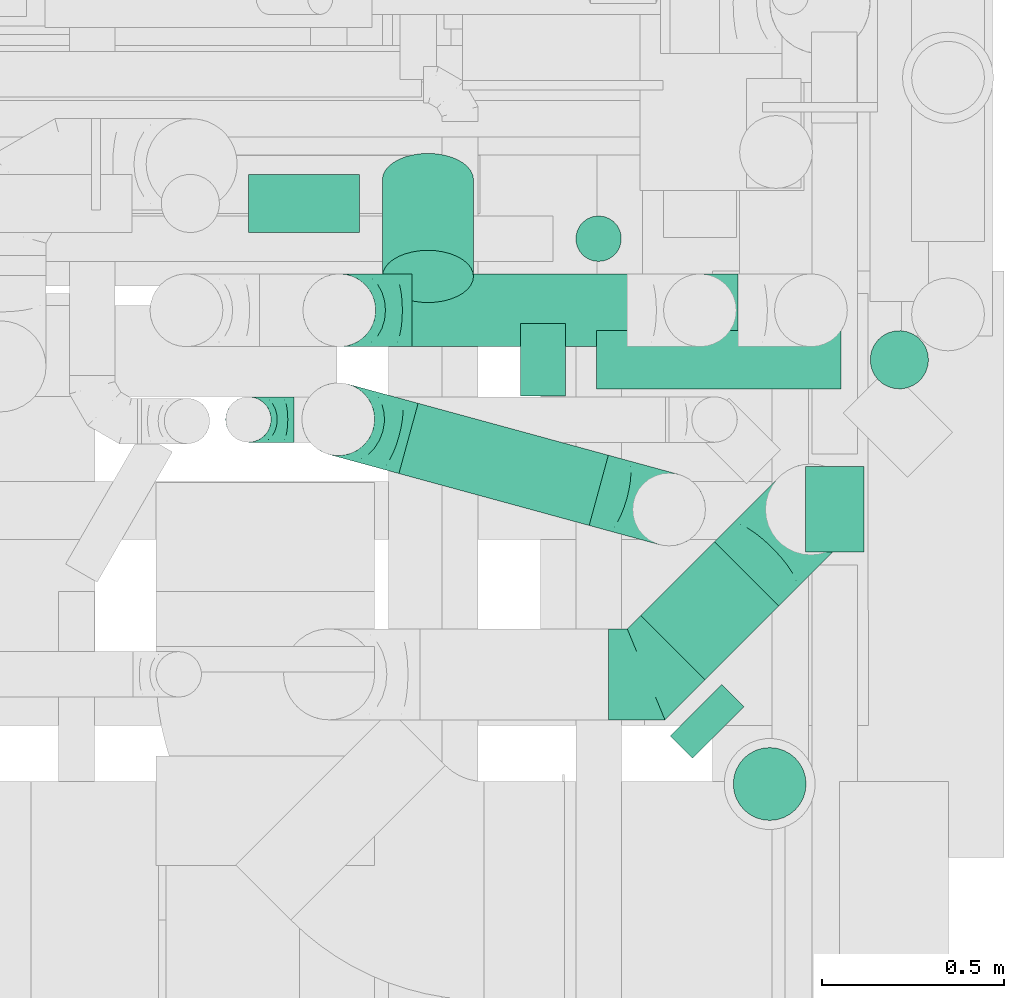
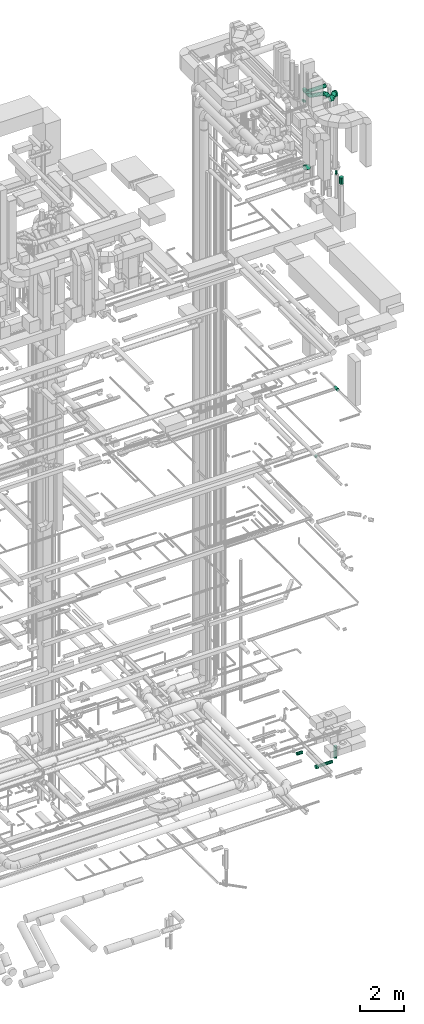
# One storey, part 300 of 337: 12 flow segments, 6 flow fittings.
"""IFC2X3 building model written with IfcOpenShell, lengths in millimetres."""

from ifc_helpers import new_model, entity, si_unit, converted_unit, derived_unit, direction, frame, origin, origin_2d_with_axis, place, context, subcontext, project, spatial, circle, extrude, faceted_brep, source, transform, mapped, material, type_object, type_shapes, element, save


model = new_model("IFC2X3")

# Units and contexts
model_context = context("Model", 3, precision=0.01, world=origin(), true_north=direction((6.12303176911189e-17, 1.0)))
body_context = subcontext(model_context, "Body", "Model", "MODEL_VIEW")
ifc_project = project(units=[si_unit("LENGTHUNIT", "METRE", prefix="MILLI"), si_unit("AREAUNIT", "SQUARE_METRE"), si_unit("VOLUMEUNIT", "CUBIC_METRE"), converted_unit("PLANEANGLEUNIT", "DEGREE", entity("IfcRatioMeasure", 0.0174532925199433), si_unit("PLANEANGLEUNIT", "RADIAN"), dimensions=[0, 0, 0, 0, 0, 0, 0]), si_unit("MASSUNIT", "GRAM", prefix="KILO"), derived_unit("MASSDENSITYUNIT", [(si_unit("MASSUNIT", "GRAM", prefix="KILO"), 1), (si_unit("LENGTHUNIT", "METRE"), -3)]), derived_unit("MOMENTOFINERTIAUNIT", [(si_unit("LENGTHUNIT", "METRE"), 4)]), si_unit("TIMEUNIT", "SECOND"), si_unit("FREQUENCYUNIT", "HERTZ"), si_unit("THERMODYNAMICTEMPERATUREUNIT", "DEGREE_CELSIUS"), derived_unit("THERMALTRANSMITTANCEUNIT", [(si_unit("MASSUNIT", "GRAM", prefix="KILO"), 1), (si_unit("THERMODYNAMICTEMPERATUREUNIT", "KELVIN"), -1), (si_unit("TIMEUNIT", "SECOND"), -3)]), derived_unit("VOLUMETRICFLOWRATEUNIT", [(si_unit("LENGTHUNIT", "METRE"), 3), (si_unit("TIMEUNIT", "SECOND"), -1)]), derived_unit("MASSFLOWRATEUNIT", [(si_unit("MASSUNIT", "GRAM", prefix="KILO"), 1), (si_unit("TIMEUNIT", "SECOND"), -1)]), derived_unit("ROTATIONALFREQUENCYUNIT", [(si_unit("TIMEUNIT", "SECOND"), -1)]), si_unit("ELECTRICCURRENTUNIT", "AMPERE"), si_unit("ELECTRICVOLTAGEUNIT", "VOLT"), si_unit("POWERUNIT", "WATT"), si_unit("FORCEUNIT", "NEWTON", prefix="KILO"), si_unit("ILLUMINANCEUNIT", "LUX"), si_unit("LUMINOUSFLUXUNIT", "LUMEN"), si_unit("LUMINOUSINTENSITYUNIT", "CANDELA"), derived_unit("USERDEFINED", [(si_unit("MASSUNIT", "GRAM", prefix="KILO"), -1), (si_unit("LENGTHUNIT", "METRE"), -2), (si_unit("TIMEUNIT", "SECOND"), 3), (si_unit("LUMINOUSFLUXUNIT", "LUMEN"), 1)]), derived_unit("LINEARVELOCITYUNIT", [(si_unit("LENGTHUNIT", "METRE"), 1), (si_unit("TIMEUNIT", "SECOND"), -1)]), si_unit("PRESSUREUNIT", "PASCAL"), derived_unit("USERDEFINED", [(si_unit("LENGTHUNIT", "METRE"), -2), (si_unit("MASSUNIT", "GRAM", prefix="KILO"), 1), (si_unit("TIMEUNIT", "SECOND"), -2)]), derived_unit("LINEARFORCEUNIT", [(si_unit("MASSUNIT", "GRAM", prefix="KILO"), 1), (si_unit("LENGTHUNIT", "METRE"), 1), (si_unit("TIMEUNIT", "SECOND"), -2), (si_unit("LENGTHUNIT", "METRE"), -1)]), derived_unit("PLANARFORCEUNIT", [(si_unit("MASSUNIT", "GRAM", prefix="KILO"), 1), (si_unit("LENGTHUNIT", "METRE"), 1), (si_unit("TIMEUNIT", "SECOND"), -2), (si_unit("LENGTHUNIT", "METRE"), -2)])], contexts=[model_context])

# Site, building, storey
site_placement = place(None, origin())
site = spatial("IfcSite", under=ifc_project, at=site_placement, CompositionType="ELEMENT")
building_placement = place(site_placement, origin())
building = spatial("IfcBuilding", under=site, at=building_placement, CompositionType="ELEMENT")
storey_placement = place(building_placement, origin())
storey = spatial("IfcBuildingStorey", under=building, at=storey_placement, CompositionType="ELEMENT", Elevation=0.0)

# Flow segments
duct_segment_type = type_object("IfcDuctSegmentType", PredefinedType="NOTDEFINED")
flow_segment_1_placement = place(storey_placement, frame((72879.66, 9130.21, -1618.0)))
element("IfcFlowSegment", 1, at=flow_segment_1_placement, inside=storey, type_object=duct_segment_type, context=body_context, shape_type="SweptSolid", body=[
    extrude(circle(Radius=80.0, at=origin_2d_with_axis()), frame((81.6, 81.6, 0.0)), (0.0, 0.0, 1.0), 658.000000000009),
])
flow_segment_2_placement = place(storey_placement, frame((71921.25, 9110.21, -1879.6)))
element("IfcFlowSegment", 2, at=flow_segment_2_placement, inside=storey, type_object=duct_segment_type, context=body_context, shape_type="SweptSolid", body=[
    extrude(circle(Radius=100.0, at=origin_2d_with_axis()), frame((0.0, 101.6, 101.6), z_axis=(1.0, 0.0, 0.0), x_axis=(0.0, 1.0, 0.0)), (0.0, 0.0, 1.0), 123.655124999988),
])
flow_segment_3_placement = place(storey_placement, frame((72129.91, 9130.21, -1859.6)))
element("IfcFlowSegment", 3, at=flow_segment_3_placement, inside=storey, type_object=duct_segment_type, context=body_context, shape_type="SweptSolid", body=[
    extrude(circle(Radius=80.0, at=origin_2d_with_axis()), frame((0.0, 81.6, 81.6), z_axis=(1.0, 0.0, 0.0), x_axis=(0.0, 1.0, 0.0)), (0.0, 0.0, 1.0), 671.344875000004),
])
flow_segment_4_placement = place(storey_placement, frame((71174.45, 9559.41, -1131.6)))
element("IfcFlowSegment", 4, at=flow_segment_4_placement, inside=storey, type_object=duct_segment_type, context=body_context, shape_type="SweptSolid", body=[
    extrude(circle(Radius=80.0, at=origin_2d_with_axis()), frame((0.0, 81.6, 81.6), z_axis=(1.0, 0.0, 0.0), x_axis=(0.0, -1.0, 0.0)), (0.0, 0.0, 1.0), 304.584560000007),
])
flow_segment_5_placement = place(storey_placement, frame((72702.56, 8683.57, 19068.4)))
element("IfcFlowSegment", 5, at=flow_segment_5_placement, inside=storey, type_object=duct_segment_type, context=body_context, shape_type="SweptSolid", body=[
    extrude(circle(Radius=80.0, at=origin_2d_with_axis()), frame((81.6, 0.0, 81.6), z_axis=(0.0, 1.0, 0.0), x_axis=(-1.0, 0.0, 0.0)), (0.0, 0.0, 1.0), 235.0),
])
flow_segment_6_placement = place(storey_placement, frame((72071.32, 9480.25, 15125.0)))
element("IfcFlowSegment", 6, at=flow_segment_6_placement, inside=storey, type_object=duct_segment_type, context=body_context, shape_type="SweptSolid", body=[
    extrude(circle(Radius=62.5, at=origin_2d_with_axis()), frame((64.1, 64.1, 0.0), z_axis=(0.0, 0.0, 1.0), x_axis=(0.0, 1.0, 0.0)), (0.0, 0.0, 1.0), 99.9999750292887),
])
flow_segment_7_placement = place(storey_placement, frame((71585.61, 8755.33, 35588.4)))
element("IfcFlowSegment", 7, at=flow_segment_7_placement, inside=storey, type_object=duct_segment_type, context=body_context, shape_type="SweptSolid", body=[
    extrude(circle(Radius=100.0, at=origin_2d_with_axis()), frame((27.92, 240.6, 101.6), z_axis=(0.964726810166191, -0.263253075474089, 0.0), x_axis=(-0.263253075474089, -0.964726810166191, 0.0)), (0.0, 0.0, 1.0), 541.414851509335),
])
flow_segment_8_placement = place(storey_placement, frame((71623.49, 9246.15, 35598.4)))
element("IfcFlowSegment", 8, at=flow_segment_8_placement, inside=storey, type_object=duct_segment_type, context=body_context, shape_type="SweptSolid", body=[
    extrude(circle(Radius=100.0, at=origin_2d_with_axis()), frame((0.0, 101.6, 101.6), z_axis=(1.0, 0.0, 0.0), x_axis=(0.0, 1.0, 0.0)), (0.0, 0.0, 1.0), 895.000000000004),
])
flow_segment_9_placement = place(storey_placement, frame((72330.33, 8116.09, 31498.4)))
element("IfcFlowSegment", 9, at=flow_segment_9_placement, inside=storey, type_object=duct_segment_type, context=body_context, shape_type="SweptSolid", body=[
    extrude(circle(Radius=100.0, at=origin_2d_with_axis()), frame((133.43, 72.31, 101.6), z_axis=(-0.707106781186472, 0.707106781186623, 0.0), x_axis=(-0.707106781186623, -0.707106781186472, 0.0)), (0.0, 0.0, 1.0), 86.4466094067538),
])
flow_segment_10_placement = place(storey_placement, frame((72503.59, 7945.38, 31040.0)))
element("IfcFlowSegment", 10, at=flow_segment_10_placement, inside=storey, type_object=duct_segment_type, context=body_context, shape_type="SweptSolid", body=[
    extrude(circle(Radius=100.0, at=origin_2d_with_axis()), frame((101.6, 101.6, 0.0), z_axis=(0.0, 0.0, 1.0), x_axis=(-0.707106781186531, 0.707106781186564, 0.0)), (0.0, 0.0, 1.0), 360.0),
])
flow_segment_11_placement = place(storey_placement, frame((71540.22, 9367.35, 31141.22)))
element("IfcFlowSegment", 11, at=flow_segment_11_placement, inside=storey, type_object=duct_segment_type, context=body_context, shape_type="SweptSolid", body=[
    extrude(circle(Radius=125.0, at=origin_2d_with_axis()), frame((126.6, 339.49, 103.99), z_axis=(0.0, -0.819152044288992, 0.573576436351046), x_axis=(-1.0, 0.0, 0.0)), (0.0, 0.0, 1.0), 324.967851138154),
])
flow_segment_12_placement = place(storey_placement, frame((72249.1, 8331.36, 35548.4)))
element("IfcFlowSegment", 12, at=flow_segment_12_placement, inside=storey, type_object=duct_segment_type, context=body_context, shape_type="SweptSolid", body=[
    extrude(circle(Radius=125.0, at=origin_2d_with_axis()), frame((89.98, 89.98, 126.6), z_axis=(0.707106781186557, 0.707106781186538, 0.0), x_axis=(0.707106781186538, -0.707106781186557, 0.0)), (0.0, 0.0, 1.0), 286.554549002885),
])

# Flow fittings
ifc_material = material()
duct_fitting_type_1 = type_object("IfcDuctFittingType", PredefinedType="NOTDEFINED", material=ifc_material)
shared_shape_1 = source(origin(), body_context, "Body", "Brep", [
    faceted_brep([(-250.0, 0.0, -125.0), (-250.0, -32.35, -120.74), (-250.0, -62.5, -108.25), (-250.0, -88.39, -88.39), (-250.0, -108.25, -62.5), (-250.0, -120.74, -32.35), (-250.0, -125.0, 0.0), (-250.0, -120.74, 32.35), (-250.0, -108.25, 62.5), (-250.0, -88.39, 88.39), (-250.0, -62.5, 108.25), (-250.0, -32.35, 120.74), (-250.0, 0.0, 125.0), (-250.0, 32.35, 120.74), (-250.0, 62.5, 108.25), (-250.0, 88.39, 88.39), (-250.0, 108.25, 62.5), (-250.0, 120.74, 32.35), (-250.0, 125.0, 0.0), (-250.0, 120.74, -32.35), (-250.0, 108.25, -62.5), (-250.0, 88.39, -88.39), (-250.0, 62.5, -108.25), (-250.0, 32.35, -120.74), (-191.68, 32.35, 120.74), (-199.76, 62.5, 108.25), (-183.01, 0.0, 125.0), (-206.7, 88.39, 88.39), (-215.37, 120.74, 32.35), (-216.51, 125.0, 0.0), (-212.02, 108.25, 62.5), (-212.02, 108.25, -62.5), (-206.7, 88.39, -88.39), (-215.37, 120.74, -32.35), (-191.68, 32.35, -120.74), (-183.01, 0.0, -125.0), (-199.76, 62.5, -108.25), (-174.34, -32.35, -120.74), (-166.27, -62.5, -108.25), (-159.33, -88.39, -88.39), (-154.01, -108.25, -62.5), (-150.66, -120.74, -32.35), (-149.52, -125.0, 0.0), (-150.66, -120.74, 32.35), (-154.01, -108.25, 62.5), (-159.33, -88.39, 88.39), (-166.27, -62.5, 108.25), (-174.34, -32.35, 120.74), (-90.67, 90.67, 120.74), (-112.74, 112.74, 108.25), (-66.99, 66.99, 125.0), (-131.69, 131.69, 88.39), (-146.23, 146.23, 62.5), (-155.38, 155.38, 32.35), (-158.49, 158.49, 0.0), (-155.38, 155.38, -32.35), (-146.23, 146.23, -62.5), (-131.69, 131.69, -88.39), (-90.67, 90.67, -120.74), (-66.99, 66.99, -125.0), (-112.74, 112.74, -108.25), (-43.3, 43.3, -120.74), (-21.23, 21.23, -108.25), (-2.28, 2.28, -88.39), (12.26, -12.26, -62.5), (21.4, -21.4, -32.35), (24.52, -24.52, 0.0), (21.4, -21.4, 32.35), (12.26, -12.26, 62.5), (-2.28, 2.28, 88.39), (-21.23, 21.23, 108.25), (-43.3, 43.3, 120.74), (-32.35, 191.68, 120.74), (-62.5, 199.76, 108.25), (0.0, 183.01, 125.0), (-88.39, 206.7, 88.39), (-108.25, 212.02, 62.5), (-120.74, 215.37, 32.35), (-125.0, 216.51, 0.0), (-120.74, 215.37, -32.35), (-108.25, 212.02, -62.5), (-88.39, 206.7, -88.39), (-32.35, 191.68, -120.74), (0.0, 183.01, -125.0), (-62.5, 199.76, -108.25), (32.35, 174.34, -120.74), (62.5, 166.27, -108.25), (88.39, 159.33, -88.39), (108.25, 154.01, -62.5), (120.74, 150.66, -32.35), (125.0, 149.52, 0.0), (120.74, 150.66, 32.35), (108.25, 154.01, 62.5), (88.39, 159.33, 88.39), (62.5, 166.27, 108.25), (32.35, 174.34, 120.74), (-32.35, 250.0, -120.74), (-62.5, 250.0, -108.25), (-88.39, 250.0, -88.39), (-108.25, 250.0, -62.5), (-120.74, 250.0, -32.35), (-125.0, 250.0, 0.0), (-120.74, 250.0, 32.35), (-108.25, 250.0, 62.5), (-88.39, 250.0, 88.39), (-62.5, 250.0, 108.25), (-32.35, 250.0, 120.74), (0.0, 250.0, 125.0), (32.35, 250.0, 120.74), (62.5, 250.0, 108.25), (88.39, 250.0, 88.39), (108.25, 250.0, 62.5), (120.74, 250.0, 32.35), (125.0, 250.0, 0.0), (120.74, 250.0, -32.35), (108.25, 250.0, -62.5), (88.39, 250.0, -88.39), (62.5, 250.0, -108.25), (32.35, 250.0, -120.74), (0.0, 250.0, -125.0)], [[[0, 1, 2, 3, 4, 5, 6, 7, 8, 9, 10, 11, 12, 13, 14, 15, 16, 17, 18, 19, 20, 21, 22, 23]], [[24, 25, 14, 13]], [[26, 24, 13, 12]], [[14, 25, 27, 15]], [[28, 29, 18, 17]], [[30, 28, 17, 16]], [[15, 27, 30, 16]], [[20, 31, 32, 21]], [[33, 31, 20, 19]], [[18, 29, 33, 19]], [[34, 35, 0, 23]], [[36, 34, 23, 22]], [[21, 32, 36, 22]], [[1, 0, 35, 37]], [[2, 1, 37, 38]], [[38, 39, 3, 2]], [[5, 4, 40, 41]], [[6, 5, 41, 42]], [[39, 40, 4, 3]], [[6, 42, 43, 7]], [[7, 43, 44, 8]], [[8, 44, 45, 9]], [[9, 45, 46, 10]], [[10, 46, 47, 11]], [[26, 12, 11, 47]], [[48, 49, 25, 24]], [[50, 48, 24, 26]], [[27, 25, 49, 51]], [[52, 53, 28, 30]], [[51, 52, 30, 27]], [[29, 28, 53, 54]], [[55, 56, 31, 33]], [[54, 55, 33, 29]], [[32, 31, 56, 57]], [[58, 59, 35, 34]], [[60, 58, 34, 36]], [[57, 60, 36, 32]], [[37, 35, 59, 61]], [[38, 37, 61, 62]], [[39, 38, 62, 63]], [[41, 40, 64, 65]], [[42, 41, 65, 66]], [[63, 64, 40, 39]], [[43, 42, 66, 67]], [[44, 43, 67, 68]], [[68, 69, 45, 44]], [[46, 45, 69, 70]], [[47, 46, 70, 71]], [[26, 47, 71, 50]], [[72, 73, 49, 48]], [[74, 72, 48, 50]], [[51, 49, 73, 75]], [[76, 77, 53, 52]], [[75, 76, 52, 51]], [[54, 53, 77, 78]], [[79, 80, 56, 55]], [[78, 79, 55, 54]], [[57, 56, 80, 81]], [[82, 83, 59, 58]], [[84, 82, 58, 60]], [[81, 84, 60, 57]], [[61, 59, 83, 85]], [[62, 61, 85, 86]], [[63, 62, 86, 87]], [[65, 64, 88, 89]], [[66, 65, 89, 90]], [[87, 88, 64, 63]], [[67, 66, 90, 91]], [[68, 67, 91, 92]], [[92, 93, 69, 68]], [[70, 69, 93, 94]], [[71, 70, 94, 95]], [[50, 71, 95, 74]], [[96, 97, 98, 99, 100, 101, 102, 103, 104, 105, 106, 107, 108, 109, 110, 111, 112, 113, 114, 115, 116, 117, 118, 119]], [[72, 74, 107, 106]], [[73, 72, 106, 105]], [[75, 73, 105, 104]], [[77, 76, 103, 102]], [[78, 77, 102, 101]], [[75, 104, 103, 76]], [[78, 101, 100, 79]], [[79, 100, 99, 80]], [[80, 99, 98, 81]], [[84, 97, 96, 82]], [[82, 96, 119, 83]], [[84, 81, 98, 97]], [[83, 119, 118, 85]], [[85, 118, 117, 86]], [[116, 87, 86, 117]], [[88, 115, 114, 89]], [[89, 114, 113, 90]], [[115, 88, 87, 116]], [[91, 90, 113, 112]], [[92, 91, 112, 111]], [[111, 110, 93, 92]], [[95, 94, 109, 108]], [[74, 95, 108, 107]], [[110, 109, 94, 93]]]),
])
type_shapes(duct_fitting_type_1, [shared_shape_1])
flow_fitting_1_placement = place(storey_placement, frame((72718.49, 8800.75, 35675.0), z_axis=(-0.707106781186577, 0.707106781186518, 0.0), x_axis=(0.707106781186518, 0.707106781186577, 0.0)))
element("IfcFlowFitting", 13, at=flow_fitting_1_placement, inside=storey, type_object=duct_fitting_type_1, material=ifc_material, context=body_context, shape_type="MappedRepresentation", body=[
    mapped(shared_shape_1, transform((0.0, 0.0, 0.0), scale=1.0)),
])
duct_fitting_type_2 = type_object("IfcDuctFittingType", PredefinedType="NOTDEFINED", material=ifc_material)
shared_shape_2 = source(origin(), body_context, "Body", "Brep", [
    faceted_brep([(-200.0, 0.0, -100.0), (-200.0, -25.88, -96.59), (-200.0, -50.0, -86.6), (-200.0, -70.71, -70.71), (-200.0, -86.6, -50.0), (-200.0, -96.59, -25.88), (-200.0, -100.0, 0.0), (-200.0, -96.59, 25.88), (-200.0, -86.6, 50.0), (-200.0, -70.71, 70.71), (-200.0, -50.0, 86.6), (-200.0, -25.88, 96.59), (-200.0, 0.0, 100.0), (-200.0, 25.88, 96.59), (-200.0, 50.0, 86.6), (-200.0, 70.71, 70.71), (-200.0, 86.6, 50.0), (-200.0, 96.59, 25.88), (-200.0, 100.0, 0.0), (-200.0, 96.59, -25.88), (-200.0, 86.6, -50.0), (-200.0, 70.71, -70.71), (-200.0, 50.0, -86.6), (-200.0, 25.88, -96.59), (-153.35, 25.88, 96.59), (-159.81, 50.0, 86.6), (-146.41, 0.0, 100.0), (-165.36, 70.71, 70.71), (-172.29, 96.59, 25.88), (-173.21, 100.0, 0.0), (-169.62, 86.6, 50.0), (-169.62, 86.6, -50.0), (-165.36, 70.71, -70.71), (-172.29, 96.59, -25.88), (-153.35, 25.88, -96.59), (-146.41, 0.0, -100.0), (-159.81, 50.0, -86.6), (-139.48, -25.88, -96.59), (-133.01, -50.0, -86.6), (-127.46, -70.71, -70.71), (-123.21, -86.6, -50.0), (-120.53, -96.59, -25.88), (-119.62, -100.0, 0.0), (-120.53, -96.59, 25.88), (-123.21, -86.6, 50.0), (-127.46, -70.71, 70.71), (-133.01, -50.0, 86.6), (-139.48, -25.88, 96.59), (-72.54, 72.54, 96.59), (-90.19, 90.19, 86.6), (-53.59, 53.59, 100.0), (-105.35, 105.35, 70.71), (-116.99, 116.99, 50.0), (-124.3, 124.3, 25.88), (-126.79, 126.79, 0.0), (-124.3, 124.3, -25.88), (-116.99, 116.99, -50.0), (-105.35, 105.35, -70.71), (-72.54, 72.54, -96.59), (-53.59, 53.59, -100.0), (-90.19, 90.19, -86.6), (-34.64, 34.64, -96.59), (-16.99, 16.99, -86.6), (-1.83, 1.83, -70.71), (9.81, -9.81, -50.0), (17.12, -17.12, -25.88), (19.62, -19.62, 0.0), (17.12, -17.12, 25.88), (9.81, -9.81, 50.0), (-1.83, 1.83, 70.71), (-16.99, 16.99, 86.6), (-34.64, 34.64, 96.59), (-25.88, 153.35, 96.59), (-50.0, 159.81, 86.6), (0.0, 146.41, 100.0), (-70.71, 165.36, 70.71), (-86.6, 169.62, 50.0), (-96.59, 172.29, 25.88), (-100.0, 173.21, 0.0), (-96.59, 172.29, -25.88), (-86.6, 169.62, -50.0), (-70.71, 165.36, -70.71), (-25.88, 153.35, -96.59), (0.0, 146.41, -100.0), (-50.0, 159.81, -86.6), (25.88, 139.48, -96.59), (50.0, 133.01, -86.6), (70.71, 127.46, -70.71), (86.6, 123.21, -50.0), (96.59, 120.53, -25.88), (100.0, 119.62, 0.0), (96.59, 120.53, 25.88), (86.6, 123.21, 50.0), (70.71, 127.46, 70.71), (50.0, 133.01, 86.6), (25.88, 139.48, 96.59), (-25.88, 200.0, -96.59), (-50.0, 200.0, -86.6), (-70.71, 200.0, -70.71), (-86.6, 200.0, -50.0), (-96.59, 200.0, -25.88), (-100.0, 200.0, 0.0), (-96.59, 200.0, 25.88), (-86.6, 200.0, 50.0), (-70.71, 200.0, 70.71), (-50.0, 200.0, 86.6), (-25.88, 200.0, 96.59), (0.0, 200.0, 100.0), (25.88, 200.0, 96.59), (50.0, 200.0, 86.6), (70.71, 200.0, 70.71), (86.6, 200.0, 50.0), (96.59, 200.0, 25.88), (100.0, 200.0, 0.0), (96.59, 200.0, -25.88), (86.6, 200.0, -50.0), (70.71, 200.0, -70.71), (50.0, 200.0, -86.6), (25.88, 200.0, -96.59), (0.0, 200.0, -100.0)], [[[0, 1, 2, 3, 4, 5, 6, 7, 8, 9, 10, 11, 12, 13, 14, 15, 16, 17, 18, 19, 20, 21, 22, 23]], [[24, 25, 14, 13]], [[26, 24, 13, 12]], [[14, 25, 27, 15]], [[28, 29, 18, 17]], [[30, 28, 17, 16]], [[15, 27, 30, 16]], [[20, 31, 32, 21]], [[33, 31, 20, 19]], [[18, 29, 33, 19]], [[34, 35, 0, 23]], [[36, 34, 23, 22]], [[32, 36, 22, 21]], [[1, 0, 35, 37]], [[2, 1, 37, 38]], [[38, 39, 3, 2]], [[5, 4, 40, 41]], [[6, 5, 41, 42]], [[39, 40, 4, 3]], [[6, 42, 43, 7]], [[7, 43, 44, 8]], [[8, 44, 45, 9]], [[9, 45, 46, 10]], [[10, 46, 47, 11]], [[26, 12, 11, 47]], [[48, 49, 25, 24]], [[50, 48, 24, 26]], [[27, 25, 49, 51]], [[52, 53, 28, 30]], [[51, 52, 30, 27]], [[29, 28, 53, 54]], [[55, 56, 31, 33]], [[54, 55, 33, 29]], [[32, 31, 56, 57]], [[58, 59, 35, 34]], [[60, 58, 34, 36]], [[57, 60, 36, 32]], [[37, 35, 59, 61]], [[38, 37, 61, 62]], [[39, 38, 62, 63]], [[41, 40, 64, 65]], [[42, 41, 65, 66]], [[63, 64, 40, 39]], [[43, 42, 66, 67]], [[44, 43, 67, 68]], [[68, 69, 45, 44]], [[46, 45, 69, 70]], [[47, 46, 70, 71]], [[26, 47, 71, 50]], [[72, 73, 49, 48]], [[74, 72, 48, 50]], [[51, 49, 73, 75]], [[76, 77, 53, 52]], [[75, 76, 52, 51]], [[54, 53, 77, 78]], [[79, 80, 56, 55]], [[78, 79, 55, 54]], [[57, 56, 80, 81]], [[82, 83, 59, 58]], [[84, 82, 58, 60]], [[81, 84, 60, 57]], [[61, 59, 83, 85]], [[62, 61, 85, 86]], [[63, 62, 86, 87]], [[65, 64, 88, 89]], [[66, 65, 89, 90]], [[87, 88, 64, 63]], [[67, 66, 90, 91]], [[68, 67, 91, 92]], [[92, 93, 69, 68]], [[70, 69, 93, 94]], [[71, 70, 94, 95]], [[50, 71, 95, 74]], [[96, 97, 98, 99, 100, 101, 102, 103, 104, 105, 106, 107, 108, 109, 110, 111, 112, 113, 114, 115, 116, 117, 118, 119]], [[72, 74, 107, 106]], [[73, 72, 106, 105]], [[75, 73, 105, 104]], [[102, 101, 78, 77]], [[103, 102, 77, 76]], [[75, 104, 103, 76]], [[78, 101, 100, 79]], [[79, 100, 99, 80]], [[80, 99, 98, 81]], [[84, 97, 96, 82]], [[82, 96, 119, 83]], [[84, 81, 98, 97]], [[118, 117, 86, 85]], [[119, 118, 85, 83]], [[116, 87, 86, 117]], [[88, 115, 114, 89]], [[89, 114, 113, 90]], [[115, 88, 87, 116]], [[91, 90, 113, 112]], [[92, 91, 112, 111]], [[111, 110, 93, 92]], [[95, 94, 109, 108]], [[74, 95, 108, 107]], [[110, 109, 94, 93]]]),
])
type_shapes(duct_fitting_type_2, [shared_shape_2])
for number, where, z_axis, x_axis in (
    (14, (71423.49, 9347.75, 35700.0), (0.0, 1.0, 0.0), (-1.0, 0.0, 0.0)),
    (15, (71420.59, 9048.58, 35690.0), (-0.263253073683208, -0.964726810654884, 0.0), (0.0, 0.0, -1.0)),
    (16, (72328.8, 8800.75, 35690.0), (-0.263253075474089, -0.964726810166191, 0.0), (0.0, 0.0, 1.0)),
):
    element("IfcFlowFitting", number, at=place(storey_placement, frame(where, z_axis=z_axis, x_axis=x_axis)), inside=storey, type_object=duct_fitting_type_2, material=ifc_material, context=body_context, shape_type="MappedRepresentation", body=[
        mapped(shared_shape_2, transform((0.0, 0.0, 0.0), scale=1.0)),
    ])
duct_fitting_type_3 = type_object("IfcDuctFittingType", PredefinedType="NOTDEFINED", material=ifc_material)
shared_shape_3 = source(origin(), body_context, "Body", "Brep", [
    faceted_brep([(-125.0, 0.0, -62.5), (-125.0, -16.18, -60.37), (-125.0, -31.25, -54.13), (-125.0, -44.19, -44.19), (-125.0, -54.13, -31.25), (-125.0, -60.37, -16.18), (-125.0, -62.5, 0.0), (-125.0, -60.37, 16.18), (-125.0, -54.13, 31.25), (-125.0, -44.19, 44.19), (-125.0, -31.25, 54.13), (-125.0, -16.18, 60.37), (-125.0, 0.0, 62.5), (-125.0, 16.18, 60.37), (-125.0, 31.25, 54.13), (-125.0, 44.19, 44.19), (-125.0, 54.13, 31.25), (-125.0, 60.37, 16.18), (-125.0, 62.5, 0.0), (-125.0, 60.37, -16.18), (-125.0, 54.13, -31.25), (-125.0, 44.19, -44.19), (-125.0, 31.25, -54.13), (-125.0, 16.18, -60.37), (-95.84, 16.18, 60.37), (-99.88, 31.25, 54.13), (-91.51, 0.0, 62.5), (-103.35, 44.19, 44.19), (-107.68, 60.37, 16.18), (-108.25, 62.5, 0.0), (-106.01, 54.13, 31.25), (-106.01, 54.13, -31.25), (-103.35, 44.19, -44.19), (-107.68, 60.37, -16.18), (-95.84, 16.18, -60.37), (-91.51, 0.0, -62.5), (-99.88, 31.25, -54.13), (-87.17, -16.18, -60.37), (-83.13, -31.25, -54.13), (-79.66, -44.19, -44.19), (-77.0, -54.13, -31.25), (-75.33, -60.37, -16.18), (-74.76, -62.5, 0.0), (-75.33, -60.37, 16.18), (-77.0, -54.13, 31.25), (-79.66, -44.19, 44.19), (-83.13, -31.25, 54.13), (-87.17, -16.18, 60.37), (-45.34, 45.34, 60.37), (-56.37, 56.37, 54.13), (-33.49, 33.49, 62.5), (-65.85, 65.85, 44.19), (-73.12, 73.12, 31.25), (-77.69, 77.69, 16.18), (-79.25, 79.25, 0.0), (-77.69, 77.69, -16.18), (-73.12, 73.12, -31.25), (-65.85, 65.85, -44.19), (-45.34, 45.34, -60.37), (-33.49, 33.49, -62.5), (-56.37, 56.37, -54.13), (-21.65, 21.65, -60.37), (-10.62, 10.62, -54.13), (-1.14, 1.14, -44.19), (6.13, -6.13, -31.25), (10.7, -10.7, -16.18), (12.26, -12.26, 0.0), (10.7, -10.7, 16.18), (6.13, -6.13, 31.25), (-1.14, 1.14, 44.19), (-10.62, 10.62, 54.13), (-21.65, 21.65, 60.37), (-16.18, 95.84, 60.37), (-31.25, 99.88, 54.13), (0.0, 91.51, 62.5), (-44.19, 103.35, 44.19), (-54.13, 106.01, 31.25), (-60.37, 107.68, 16.18), (-62.5, 108.25, 0.0), (-60.37, 107.68, -16.18), (-54.13, 106.01, -31.25), (-44.19, 103.35, -44.19), (-16.18, 95.84, -60.37), (0.0, 91.51, -62.5), (-31.25, 99.88, -54.13), (16.18, 87.17, -60.37), (31.25, 83.13, -54.13), (44.19, 79.66, -44.19), (54.13, 77.0, -31.25), (60.37, 75.33, -16.18), (62.5, 74.76, 0.0), (60.37, 75.33, 16.18), (54.13, 77.0, 31.25), (44.19, 79.66, 44.19), (31.25, 83.13, 54.13), (16.18, 87.17, 60.37), (-16.18, 125.0, -60.37), (-31.25, 125.0, -54.13), (-44.19, 125.0, -44.19), (-54.13, 125.0, -31.25), (-60.37, 125.0, -16.18), (-62.5, 125.0, 0.0), (-60.37, 125.0, 16.18), (-54.13, 125.0, 31.25), (-44.19, 125.0, 44.19), (-31.25, 125.0, 54.13), (-16.18, 125.0, 60.37), (0.0, 125.0, 62.5), (16.18, 125.0, 60.37), (31.25, 125.0, 54.13), (44.19, 125.0, 44.19), (54.13, 125.0, 31.25), (60.37, 125.0, 16.18), (62.5, 125.0, 0.0), (60.37, 125.0, -16.18), (54.13, 125.0, -31.25), (44.19, 125.0, -44.19), (31.25, 125.0, -54.13), (16.18, 125.0, -60.37), (0.0, 125.0, -62.5)], [[[0, 1, 2, 3, 4, 5, 6, 7, 8, 9, 10, 11, 12, 13, 14, 15, 16, 17, 18, 19, 20, 21, 22, 23]], [[24, 25, 14, 13]], [[26, 24, 13, 12]], [[14, 25, 27, 15]], [[28, 29, 18, 17]], [[30, 28, 17, 16]], [[15, 27, 30, 16]], [[20, 31, 32, 21]], [[33, 31, 20, 19]], [[18, 29, 33, 19]], [[34, 35, 0, 23]], [[36, 34, 23, 22]], [[21, 32, 36, 22]], [[1, 0, 35, 37]], [[2, 1, 37, 38]], [[38, 39, 3, 2]], [[5, 4, 40, 41]], [[6, 5, 41, 42]], [[39, 40, 4, 3]], [[6, 42, 43, 7]], [[7, 43, 44, 8]], [[45, 9, 8, 44]], [[9, 45, 46, 10]], [[10, 46, 47, 11]], [[26, 12, 11, 47]], [[48, 49, 25, 24]], [[50, 48, 24, 26]], [[27, 25, 49, 51]], [[52, 53, 28, 30]], [[51, 52, 30, 27]], [[29, 28, 53, 54]], [[55, 56, 31, 33]], [[54, 55, 33, 29]], [[57, 32, 31, 56]], [[58, 59, 35, 34]], [[60, 58, 34, 36]], [[57, 60, 36, 32]], [[37, 35, 59, 61]], [[38, 37, 61, 62]], [[39, 38, 62, 63]], [[41, 40, 64, 65]], [[42, 41, 65, 66]], [[63, 64, 40, 39]], [[43, 42, 66, 67]], [[44, 43, 67, 68]], [[68, 69, 45, 44]], [[46, 45, 69, 70]], [[47, 46, 70, 71]], [[26, 47, 71, 50]], [[72, 73, 49, 48]], [[74, 72, 48, 50]], [[51, 49, 73, 75]], [[76, 77, 53, 52]], [[75, 76, 52, 51]], [[54, 53, 77, 78]], [[79, 80, 56, 55]], [[78, 79, 55, 54]], [[81, 57, 56, 80]], [[82, 83, 59, 58]], [[84, 82, 58, 60]], [[81, 84, 60, 57]], [[61, 59, 83, 85]], [[62, 61, 85, 86]], [[63, 62, 86, 87]], [[65, 64, 88, 89]], [[66, 65, 89, 90]], [[87, 88, 64, 63]], [[67, 66, 90, 91]], [[68, 67, 91, 92]], [[92, 93, 69, 68]], [[70, 69, 93, 94]], [[71, 70, 94, 95]], [[50, 71, 95, 74]], [[96, 97, 98, 99, 100, 101, 102, 103, 104, 105, 106, 107, 108, 109, 110, 111, 112, 113, 114, 115, 116, 117, 118, 119]], [[72, 74, 107, 106]], [[73, 72, 106, 105]], [[75, 73, 105, 104]], [[77, 76, 103, 102]], [[78, 77, 102, 101]], [[75, 104, 103, 76]], [[78, 101, 100, 79]], [[79, 100, 99, 80]], [[80, 99, 98, 81]], [[96, 119, 83, 82]], [[97, 96, 82, 84]], [[84, 81, 98, 97]], [[83, 119, 118, 85]], [[85, 118, 117, 86]], [[116, 87, 86, 117]], [[88, 115, 114, 89]], [[89, 114, 113, 90]], [[115, 88, 87, 116]], [[91, 90, 113, 112]], [[92, 91, 112, 111]], [[111, 110, 93, 92]], [[95, 94, 109, 108]], [[74, 95, 108, 107]], [[110, 109, 94, 93]]]),
])
type_shapes(duct_fitting_type_3, [shared_shape_3])
flow_fitting_2_placement = place(storey_placement, frame((71173.8, 9047.75, 35450.0), z_axis=(0.0, 1.0, 0.0), x_axis=(-1.0, 0.0, 0.0)))
element("IfcFlowFitting", 17, at=flow_fitting_2_placement, inside=storey, type_object=duct_fitting_type_3, material=ifc_material, context=body_context, shape_type="MappedRepresentation", body=[
    mapped(shared_shape_3, transform((0.0, 0.0, 0.0), scale=1.0)),
])
duct_fitting_type_4 = type_object("IfcDuctFittingType", PredefinedType="NOTDEFINED", material=ifc_material)
shared_shape_4 = source(origin(), body_context, "Body", "Brep", [
    faceted_brep([(-103.55, 0.0, -125.0), (-103.55, -32.35, -120.74), (-103.55, -62.5, -108.25), (-103.55, -88.39, -88.39), (-103.55, -108.25, -62.5), (-103.55, -120.74, -32.35), (-103.55, -125.0, 0.0), (-103.55, -120.74, 32.35), (-103.55, -108.25, 62.5), (-103.55, -88.39, 88.39), (-103.55, -62.5, 108.25), (-103.55, -32.35, 120.74), (-103.55, 0.0, 125.0), (-103.55, 32.35, 120.74), (-103.55, 62.5, 108.25), (-103.55, 88.39, 88.39), (-103.55, 108.25, 62.5), (-103.55, 120.74, 32.35), (-103.55, 125.0, 0.0), (-103.55, 120.74, -32.35), (-103.55, 108.25, -62.5), (-103.55, 88.39, -88.39), (-103.55, 62.5, -108.25), (-103.55, 32.35, -120.74), (-13.4, 32.35, 120.74), (-25.89, 62.5, 108.25), (0.0, 0.0, 125.0), (-36.61, 88.39, 88.39), (-44.84, 108.25, 62.5), (-50.01, 120.74, 32.35), (-51.78, 125.0, 0.0), (-50.01, 120.74, -32.35), (-44.84, 108.25, -62.5), (-36.61, 88.39, -88.39), (-13.4, 32.35, -120.74), (0.0, 0.0, -125.0), (-25.89, 62.5, -108.25), (13.4, -32.35, -120.74), (25.89, -62.5, -108.25), (36.61, -88.39, -88.39), (44.84, -108.25, -62.5), (50.01, -120.74, -32.35), (51.78, -125.0, 0.0), (50.01, -120.74, 32.35), (44.84, -108.25, 62.5), (36.61, -88.39, 88.39), (25.89, -62.5, 108.25), (13.4, -32.35, 120.74), (73.22, 73.22, 125.0), (50.35, 96.1, 120.74), (29.03, 117.42, 108.25), (10.72, 135.72, 88.39), (-3.32, 149.77, 62.5), (-12.15, 158.6, 32.35), (-15.17, 161.61, 0.0), (-12.15, 158.6, -32.35), (-3.32, 149.77, -62.5), (10.72, 135.72, -88.39), (29.03, 117.42, -108.25), (50.35, 96.1, -120.74), (73.22, 73.22, -125.0), (96.1, 50.35, -120.74), (117.42, 29.03, -108.25), (135.72, 10.72, -88.39), (149.77, -3.32, -62.5), (158.6, -12.15, -32.35), (161.61, -15.17, 0.0), (158.6, -12.15, 32.35), (149.77, -3.32, 62.5), (135.72, 10.72, 88.39), (117.42, 29.03, 108.25), (96.1, 50.35, 120.74)], [[[0, 1, 2, 3, 4, 5, 6, 7, 8, 9, 10, 11, 12, 13, 14, 15, 16, 17, 18, 19, 20, 21, 22, 23]], [[24, 25, 14, 13]], [[26, 24, 13, 12]], [[14, 25, 27, 15]], [[28, 29, 17, 16]], [[28, 16, 15, 27]], [[30, 18, 17, 29]], [[31, 32, 20, 19]], [[30, 31, 19, 18]], [[32, 33, 21, 20]], [[34, 35, 0, 23]], [[36, 34, 23, 22]], [[33, 36, 22, 21]], [[1, 0, 35, 37]], [[2, 1, 37, 38]], [[38, 39, 3, 2]], [[5, 4, 40, 41]], [[6, 5, 41, 42]], [[39, 40, 4, 3]], [[6, 42, 43, 7]], [[7, 43, 44, 8]], [[8, 44, 45, 9]], [[9, 45, 46, 10]], [[10, 46, 47, 11]], [[26, 12, 11, 47]], [[24, 26, 48, 49]], [[25, 24, 49, 50]], [[27, 25, 50, 51]], [[29, 28, 52, 53]], [[30, 29, 53, 54]], [[51, 52, 28, 27]], [[30, 54, 55, 31]], [[31, 55, 56, 32]], [[57, 33, 32, 56]], [[36, 58, 59, 34]], [[34, 59, 60, 35]], [[58, 36, 33, 57]], [[35, 60, 61, 37]], [[37, 61, 62, 38]], [[63, 39, 38, 62]], [[40, 64, 65, 41]], [[41, 65, 66, 42]], [[64, 40, 39, 63]], [[43, 42, 66, 67]], [[44, 43, 67, 68]], [[68, 69, 45, 44]], [[47, 46, 70, 71]], [[26, 47, 71, 48]], [[69, 70, 46, 45]], [[59, 58, 57, 56, 55, 54, 53, 52, 51, 50, 49, 48, 71, 70, 69, 68, 67, 66, 65, 64, 63, 62, 61, 60]]]),
])
type_shapes(duct_fitting_type_4, [shared_shape_4])
flow_fitting_3_placement = place(storey_placement, frame((72265.86, 8348.12, 35675.0)))
element("IfcFlowFitting", 18, at=flow_fitting_3_placement, inside=storey, type_object=duct_fitting_type_4, material=ifc_material, context=body_context, shape_type="MappedRepresentation", body=[
    mapped(shared_shape_4, transform((0.0, 0.0, 0.0), scale=1.0)),
])

save(model, "model.ifc")
